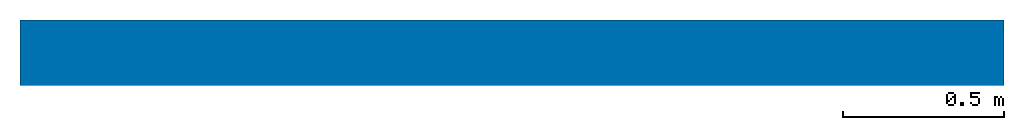
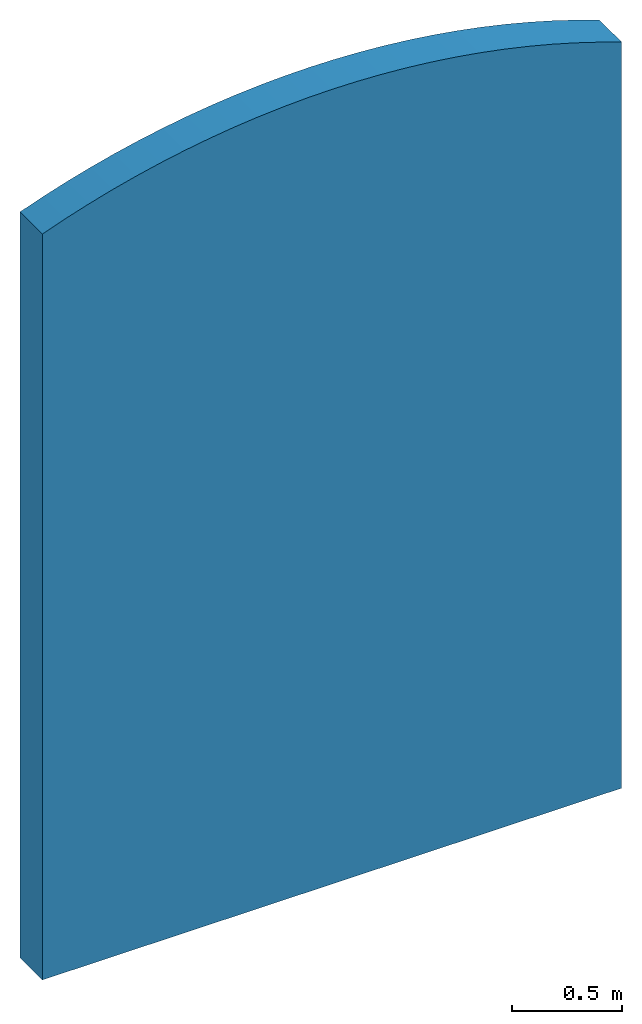
# One storey: 1 wall.
"""IFC4 building model written with IfcOpenShell, lengths in feet."""

from ifc_helpers import new_model, entity, si_unit, converted_unit, derived_unit, direction, origin, place, context, subcontext, project, spatial, material, layer, layer_set, type_object, element, save


model = new_model("IFC4")

# Units and contexts
model_context = context("Model", 3, precision=0.0001, world=origin(), true_north=direction((6.12303176911189e-17, 1.0)))
body_context = subcontext(model_context, "Body", "Model", "MODEL_VIEW")
ifc_project = project(units=[converted_unit("LENGTHUNIT", "FOOT", entity("IfcRatioMeasure", 0.3048), si_unit("LENGTHUNIT", "METRE"), dimensions=[1, 0, 0, 0, 0, 0, 0]), converted_unit("AREAUNIT", "SQUARE FOOT", entity("IfcRatioMeasure", 0.09290304), si_unit("AREAUNIT", "SQUARE_METRE"), dimensions=[2, 0, 0, 0, 0, 0, 0]), converted_unit("VOLUMEUNIT", "CUBIC FOOT", entity("IfcRatioMeasure", 0.028316846592), si_unit("VOLUMEUNIT", "CUBIC_METRE"), dimensions=[3, 0, 0, 0, 0, 0, 0]), converted_unit("PLANEANGLEUNIT", "DEGREE", entity("IfcRatioMeasure", 0.0174532925199433), si_unit("PLANEANGLEUNIT", "RADIAN"), dimensions=[0, 0, 0, 0, 0, 0, 0]), si_unit("MASSUNIT", "GRAM", prefix="KILO"), derived_unit("MASSDENSITYUNIT", [(si_unit("MASSUNIT", "GRAM", prefix="KILO"), 1), (si_unit("LENGTHUNIT", "METRE"), -3)]), derived_unit("MOMENTOFINERTIAUNIT", [(si_unit("LENGTHUNIT", "METRE"), 4)]), si_unit("TIMEUNIT", "SECOND"), si_unit("FREQUENCYUNIT", "HERTZ"), si_unit("THERMODYNAMICTEMPERATUREUNIT", "DEGREE_CELSIUS"), derived_unit("THERMALTRANSMITTANCEUNIT", [(si_unit("MASSUNIT", "GRAM", prefix="KILO"), 1), (si_unit("THERMODYNAMICTEMPERATUREUNIT", "KELVIN"), -1), (si_unit("TIMEUNIT", "SECOND"), -3)]), derived_unit("VOLUMETRICFLOWRATEUNIT", [(si_unit("LENGTHUNIT", "METRE"), 3), (si_unit("TIMEUNIT", "SECOND"), -1)]), si_unit("ELECTRICCURRENTUNIT", "AMPERE"), si_unit("ELECTRICVOLTAGEUNIT", "VOLT"), si_unit("POWERUNIT", "WATT"), si_unit("FORCEUNIT", "NEWTON"), si_unit("ILLUMINANCEUNIT", "LUX"), si_unit("LUMINOUSFLUXUNIT", "LUMEN"), si_unit("LUMINOUSINTENSITYUNIT", "CANDELA"), derived_unit("USERDEFINED", [(si_unit("MASSUNIT", "GRAM", prefix="KILO"), -1), (si_unit("LENGTHUNIT", "METRE"), -2), (si_unit("TIMEUNIT", "SECOND"), 3), (si_unit("LUMINOUSFLUXUNIT", "LUMEN"), 1)]), derived_unit("LINEARVELOCITYUNIT", [(si_unit("LENGTHUNIT", "METRE"), 1), (si_unit("TIMEUNIT", "SECOND"), -1)]), si_unit("PRESSUREUNIT", "PASCAL"), derived_unit("USERDEFINED", [(si_unit("LENGTHUNIT", "METRE"), -2), (si_unit("MASSUNIT", "GRAM", prefix="KILO"), 1), (si_unit("TIMEUNIT", "SECOND"), -2)]), derived_unit("LINEARFORCEUNIT", [(si_unit("MASSUNIT", "GRAM", prefix="KILO"), 1), (si_unit("LENGTHUNIT", "METRE"), 1), (si_unit("TIMEUNIT", "SECOND"), -2), (si_unit("LENGTHUNIT", "METRE"), -1)]), derived_unit("PLANARFORCEUNIT", [(si_unit("MASSUNIT", "GRAM", prefix="KILO"), 1), (si_unit("LENGTHUNIT", "METRE"), 1), (si_unit("TIMEUNIT", "SECOND"), -2), (si_unit("LENGTHUNIT", "METRE"), -2)])], contexts=[model_context])

# Site, building, storey
site_placement = place(None, origin())
site = spatial("IfcSite", under=ifc_project, at=site_placement, CompositionType="ELEMENT")
building_placement = place(site_placement, origin())
building = spatial("IfcBuilding", under=site, at=building_placement, CompositionType="ELEMENT")
storey_placement = place(building_placement, origin())
storey = spatial("IfcBuildingStorey", under=building, at=storey_placement, Name="Level 1", CompositionType="ELEMENT", Elevation=0.0)

# Wall
ifc_material_1 = material(Name="1", Category="Materials")
ifc_layer_1 = layer(ifc_material_1, 0.333333333333333, Name="1", Category="Materials")
ifc_material_2 = material(Name="2", Category="Materials")
ifc_layer_2 = layer(ifc_material_2, 0.333333333333333, Name="2", Category="Materials")
ifc_layer_set = layer_set([ifc_layer_1, ifc_layer_2])
wall_type = type_object("IfcWallType", PredefinedType="STANDARD", material=ifc_layer_set)
wall_placement = place(storey_placement, origin())
cartesian_point_1 = entity("IfcCartesianPoint", [0.0, -0.333333333333333, 0.0])
vertex_point_1 = entity("IfcVertexPoint", cartesian_point_1)
cartesian_point_2 = entity("IfcCartesianPoint", [10.0, -0.333333333333333, 0.0])
vertex_point_2 = entity("IfcVertexPoint", cartesian_point_2)
ifc_direction_1 = entity("IfcDirection", [1.0, 0.0, 0.0])
edge_curve_1 = entity("IfcEdgeCurve", vertex_point_1, vertex_point_2, entity("IfcTrimmedCurve", entity("IfcLine", cartesian_point_1, entity("IfcVector", ifc_direction_1, 1.0)), [cartesian_point_1], [cartesian_point_2], True, "CARTESIAN"), True)
cartesian_point_3 = entity("IfcCartesianPoint", [10.0, -0.333333333333333, 13.6106575888162])
vertex_point_3 = entity("IfcVertexPoint", cartesian_point_3)
ifc_direction_2 = entity("IfcDirection", [0.0, 0.0, 1.0])
edge_curve_2 = entity("IfcEdgeCurve", vertex_point_2, vertex_point_3, entity("IfcTrimmedCurve", entity("IfcLine", cartesian_point_2, entity("IfcVector", ifc_direction_2, 1.0)), [cartesian_point_2], [cartesian_point_3], True, "CARTESIAN"), True)
cartesian_point_4 = entity("IfcCartesianPoint", [0.0, -0.333333333333333, 13.6106575888162])
vertex_point_4 = entity("IfcVertexPoint", cartesian_point_4)
ifc_direction_3 = entity("IfcDirection", [0.0, -1.0, 0.0])
edge_curve_3 = entity("IfcEdgeCurve", vertex_point_3, vertex_point_4, entity("IfcTrimmedCurve", entity("IfcCircle", entity("IfcAxis2Placement3D", entity("IfcCartesianPoint", [5.0, -0.333333333333333, 0.0]), ifc_direction_3, ifc_direction_1), 14.5), [cartesian_point_3], [cartesian_point_4], True, "CARTESIAN"), True)
ifc_direction_4 = entity("IfcDirection", [0.0, 0.0, -1.0])
edge_curve_4 = entity("IfcEdgeCurve", vertex_point_4, vertex_point_1, entity("IfcTrimmedCurve", entity("IfcLine", cartesian_point_4, entity("IfcVector", ifc_direction_4, 1.0)), [cartesian_point_4], [cartesian_point_1], True, "CARTESIAN"), True)
cartesian_point_5 = entity("IfcCartesianPoint", [0.0, 0.333333333333333, 0.0])
vertex_point_5 = entity("IfcVertexPoint", cartesian_point_5)
cartesian_point_6 = entity("IfcCartesianPoint", [0.0, 0.333333333333333, 13.6106575888162])
vertex_point_6 = entity("IfcVertexPoint", cartesian_point_6)
edge_curve_5 = entity("IfcEdgeCurve", vertex_point_5, vertex_point_6, entity("IfcTrimmedCurve", entity("IfcLine", cartesian_point_5, entity("IfcVector", ifc_direction_2, 1.0)), [cartesian_point_5], [cartesian_point_6], True, "CARTESIAN"), True)
cartesian_point_7 = entity("IfcCartesianPoint", [10.0, 0.333333333333333, 13.6106575888162])
vertex_point_7 = entity("IfcVertexPoint", cartesian_point_7)
ifc_direction_5 = entity("IfcDirection", [0.0, 1.0, 0.0])
edge_curve_6 = entity("IfcEdgeCurve", vertex_point_6, vertex_point_7, entity("IfcTrimmedCurve", entity("IfcCircle", entity("IfcAxis2Placement3D", entity("IfcCartesianPoint", [5.0, 0.333333333333333, 0.0]), ifc_direction_5, ifc_direction_1), 14.5), [cartesian_point_6], [cartesian_point_7], True, "CARTESIAN"), True)
cartesian_point_8 = entity("IfcCartesianPoint", [10.0, 0.333333333333333, 0.0])
vertex_point_8 = entity("IfcVertexPoint", cartesian_point_8)
edge_curve_7 = entity("IfcEdgeCurve", vertex_point_7, vertex_point_8, entity("IfcTrimmedCurve", entity("IfcLine", cartesian_point_7, entity("IfcVector", ifc_direction_4, 1.0)), [cartesian_point_7], [cartesian_point_8], True, "CARTESIAN"), True)
ifc_direction_6 = entity("IfcDirection", [-1.0, 0.0, 0.0])
edge_curve_8 = entity("IfcEdgeCurve", vertex_point_8, vertex_point_5, entity("IfcTrimmedCurve", entity("IfcLine", cartesian_point_8, entity("IfcVector", ifc_direction_6, 1.0)), [cartesian_point_8], [cartesian_point_5], True, "CARTESIAN"), True)
edge_curve_9 = entity("IfcEdgeCurve", vertex_point_1, vertex_point_5, entity("IfcTrimmedCurve", entity("IfcLine", cartesian_point_1, entity("IfcVector", ifc_direction_5, 1.0)), [cartesian_point_1], [cartesian_point_5], True, "CARTESIAN"), True)
edge_curve_10 = entity("IfcEdgeCurve", vertex_point_8, vertex_point_2, entity("IfcTrimmedCurve", entity("IfcLine", cartesian_point_2, entity("IfcVector", ifc_direction_3, 1.0)), [cartesian_point_8], [cartesian_point_2], True, "CARTESIAN"), True)
edge_curve_11 = entity("IfcEdgeCurve", vertex_point_7, vertex_point_3, entity("IfcTrimmedCurve", entity("IfcLine", cartesian_point_7, entity("IfcVector", ifc_direction_3, 1.0)), [cartesian_point_7], [cartesian_point_3], True, "CARTESIAN"), True)
edge_curve_12 = entity("IfcEdgeCurve", vertex_point_4, vertex_point_6, entity("IfcTrimmedCurve", entity("IfcLine", cartesian_point_4, entity("IfcVector", ifc_direction_5, 1.0)), [cartesian_point_4], [cartesian_point_6], True, "CARTESIAN"), True)
element("IfcWall", 1, at=wall_placement, inside=storey, type_object=wall_type, PredefinedType="NOTDEFINED", context=body_context, shape_type="AdvancedBrep", body=[
    entity("IfcAdvancedBrep", entity("IfcClosedShell", [entity("IfcAdvancedFace", [entity("IfcFaceOuterBound", entity("IfcEdgeLoop", [entity("IfcOrientedEdge", None, None, edge_curve_1, True), entity("IfcOrientedEdge", None, None, edge_curve_2, True), entity("IfcOrientedEdge", None, None, edge_curve_3, True), entity("IfcOrientedEdge", None, None, edge_curve_4, True)]), True)], entity("IfcPlane", entity("IfcAxis2Placement3D", cartesian_point_1, ifc_direction_3, ifc_direction_1)), True), entity("IfcAdvancedFace", [entity("IfcFaceOuterBound", entity("IfcEdgeLoop", [entity("IfcOrientedEdge", None, None, edge_curve_5, True), entity("IfcOrientedEdge", None, None, edge_curve_6, True), entity("IfcOrientedEdge", None, None, edge_curve_7, True), entity("IfcOrientedEdge", None, None, edge_curve_8, True)]), True)], entity("IfcPlane", entity("IfcAxis2Placement3D", cartesian_point_5, ifc_direction_5, ifc_direction_6)), True), entity("IfcAdvancedFace", [entity("IfcFaceOuterBound", entity("IfcEdgeLoop", [entity("IfcOrientedEdge", None, None, edge_curve_1, False), entity("IfcOrientedEdge", None, None, edge_curve_9, True), entity("IfcOrientedEdge", None, None, edge_curve_8, False), entity("IfcOrientedEdge", None, None, edge_curve_10, True)]), True)], entity("IfcPlane", entity("IfcAxis2Placement3D", cartesian_point_1, ifc_direction_4, ifc_direction_5)), True), entity("IfcAdvancedFace", [entity("IfcFaceOuterBound", entity("IfcEdgeLoop", [entity("IfcOrientedEdge", None, None, edge_curve_2, False), entity("IfcOrientedEdge", None, None, edge_curve_10, False), entity("IfcOrientedEdge", None, None, edge_curve_7, False), entity("IfcOrientedEdge", None, None, edge_curve_11, True)]), True)], entity("IfcPlane", entity("IfcAxis2Placement3D", cartesian_point_2, ifc_direction_1, ifc_direction_5)), True), entity("IfcAdvancedFace", [entity("IfcFaceOuterBound", entity("IfcEdgeLoop", [entity("IfcOrientedEdge", None, None, edge_curve_4, False), entity("IfcOrientedEdge", None, None, edge_curve_12, True), entity("IfcOrientedEdge", None, None, edge_curve_5, False), entity("IfcOrientedEdge", None, None, edge_curve_9, False)]), True)], entity("IfcPlane", entity("IfcAxis2Placement3D", entity("IfcCartesianPoint", [0.0, -0.333333333333333, 10.0]), ifc_direction_6, ifc_direction_5)), True), entity("IfcAdvancedFace", [entity("IfcFaceOuterBound", entity("IfcEdgeLoop", [entity("IfcOrientedEdge", None, None, edge_curve_3, False), entity("IfcOrientedEdge", None, None, edge_curve_11, False), entity("IfcOrientedEdge", None, None, edge_curve_6, False), entity("IfcOrientedEdge", None, None, edge_curve_12, False)]), True)], entity("IfcCylindricalSurface", entity("IfcAxis2Placement3D", entity("IfcCartesianPoint", [5.0, 7.80875588213335, 0.0]), ifc_direction_5, ifc_direction_1), 14.5), True)])),
])

save(model, "model.ifc")
